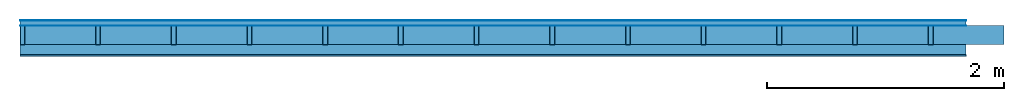
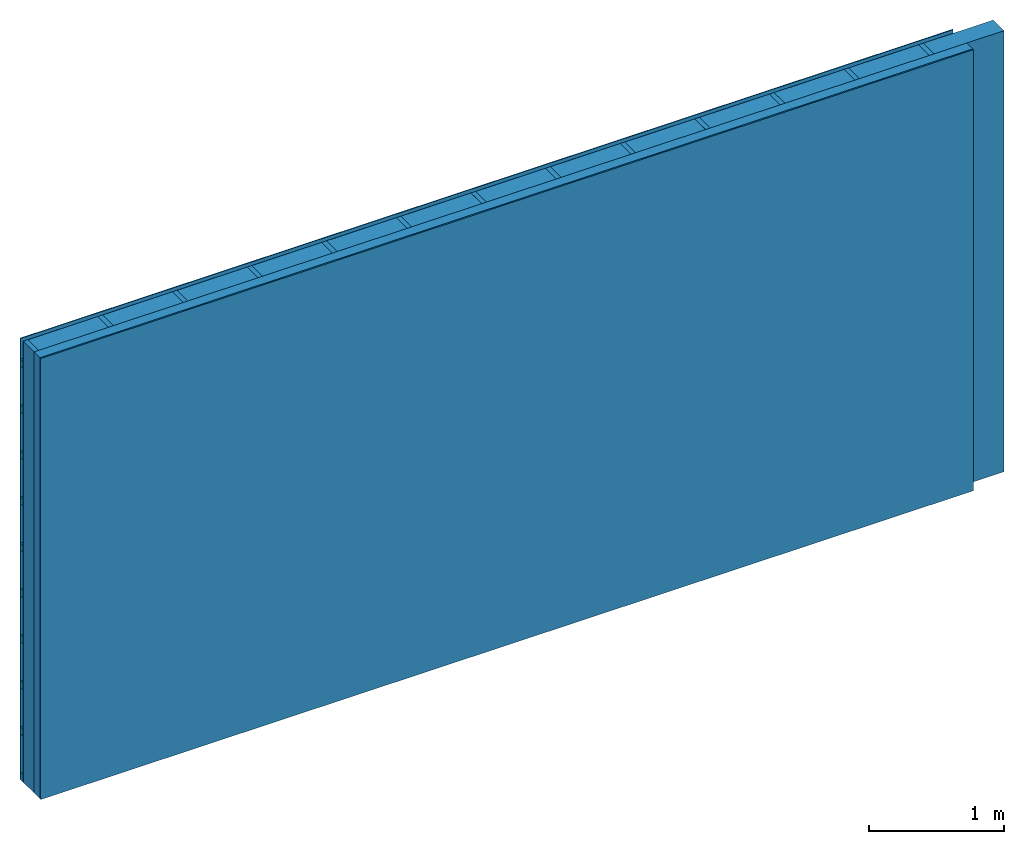
# One storey: 4 plates, 3 members, 1 element without a shape of its own.
"""IFC4 building model written with IfcOpenShell, lengths in metres."""

from ifc_helpers import new_model, si_unit, derived_unit, direction, frame, frame_2d, origin, origin_with_axes, place, context, project, spatial, rectangle, extrude, material, layer, layer_set, type_object, element, aggregate, save


model = new_model("IFC4")

# Units and contexts
plan_context = context("Plan", 3, precision=1e-05, world=origin(), true_north=direction((0.0, 1.0)))
model_context = context("Model", 3, precision=1e-05, world=origin(), true_north=direction((0.0, 1.0)))
ifc_project = project(units=[si_unit("LENGTHUNIT", "METRE"), derived_unit("SOUNDPRESSUREUNIT", [(si_unit("PRESSUREUNIT", "PASCAL", prefix="MICRO"), 0)]), si_unit("ENERGYUNIT", "JOULE", prefix="MEGA"), si_unit("MASSUNIT", "GRAM", prefix="KILO"), derived_unit("THERMALTRANSMITTANCEUNIT", [(si_unit("POWERUNIT", "WATT"), 1), (si_unit("AREAUNIT", "SQUARE_METRE"), -1), (si_unit("THERMODYNAMICTEMPERATUREUNIT", "KELVIN"), -1)]), derived_unit("AREADENSITYUNIT", [(si_unit("MASSUNIT", "GRAM", prefix="KILO"), 1), (si_unit("AREAUNIT", "SQUARE_METRE"), -1)]), derived_unit("USERDEFINED", [(si_unit("ENERGYUNIT", "JOULE", prefix="MEGA"), 1), (si_unit("AREAUNIT", "SQUARE_METRE"), -1)])], contexts=[plan_context, model_context])

# Site, building, storey
site = spatial("IfcSite", under=ifc_project)
building_placement = place(None, origin())
building = spatial("IfcBuilding", under=site, at=building_placement)
storey_placement = place(building_placement, origin())
storey = spatial("IfcBuildingStorey", under=building, at=storey_placement)

# Wall, members, plates
ifc_material_1 = material(Name="mineral, cement-based building board", Category="03.003")
ifc_layer_1 = layer(ifc_material_1, 0.008, Name="Cover 1st layer")
ifc_layer_2 = layer(None, 0.04, Name="Battens / profiles (ventilation)")
ifc_material_2 = material(Name="Vapor-permeable water barrier", Category="09.006")
ifc_layer_3 = layer(ifc_material_2, 0.0005, Name="outside 1st layer")
ifc_material_3 = material(Name="of the art")
ifc_layer_4 = layer(ifc_material_3, 0.0, Name="Bond")
ifc_layer_5 = layer(None, 0.16, Name="Support")
ifc_layer_6 = layer(ifc_material_3, 0.0, Name="Bond")
ifc_material_4 = material(Name="Solid timber panel")
ifc_layer_7 = layer(ifc_material_4, 0.087, Name="1st layer")
ifc_material_5 = material(Name="Plasterboard type A", Category="03.008")
ifc_layer_8 = layer(ifc_material_5, 0.0125, Name="Covering 1st layer")
ifc_material_6 = material(Name="joints", Category="04.017")
ifc_layer_9 = layer(ifc_material_6, 0.0, Name="Surface")
ifc_layer_set = layer_set([ifc_layer_1, ifc_layer_2, ifc_layer_3, ifc_layer_4, ifc_layer_5, ifc_layer_6, ifc_layer_7, ifc_layer_8, ifc_layer_9])
wall_type = type_object("IfcWallType", Name="D0994", PredefinedType="NOTDEFINED", material=ifc_layer_set)
wall_placement = place(None, frame((0.0, 0.0, 0.0), z_axis=(0.0, -1.0, 0.0), x_axis=(1.0, 0.0, 0.0)))
wall = element("IfcWall", 1, at=wall_placement, inside=storey, type_object=wall_type, material=ifc_layer_set, Name="Wall #1")
ifc_material_7 = material()
member_1_placement = place(wall_placement, origin())
member_1 = element("IfcMember", 2, at=member_1_placement, material=ifc_material_7, Name="Battens / profiles (ventilation)", context=plan_context, shape_type="SweptSolid", body=[
    extrude(rectangle(XDim=0.06, YDim=0.04, at=frame_2d((0.03, 0.02), x_axis=(1.0, 0.0))), frame((0.0, 0.0, 0.008), z_axis=(1.0, 0.0, 0.0), x_axis=(0.0, 1.0, 0.0)), (0.0, 0.0, 1.0), 8.0),
    extrude(rectangle(XDim=0.06, YDim=0.04, at=frame_2d((0.03, 0.02), x_axis=(1.0, 0.0))), frame((0.0, 0.417, 0.008), z_axis=(1.0, 0.0, 0.0), x_axis=(0.0, 1.0, 0.0)), (0.0, 0.0, 1.0), 8.0),
    extrude(rectangle(XDim=0.06, YDim=0.04, at=frame_2d((0.03, 0.02), x_axis=(1.0, 0.0))), frame((0.0, 0.834, 0.008), z_axis=(1.0, 0.0, 0.0), x_axis=(0.0, 1.0, 0.0)), (0.0, 0.0, 1.0), 8.0),
    extrude(rectangle(XDim=0.06, YDim=0.04, at=frame_2d((0.03, 0.02), x_axis=(1.0, 0.0))), frame((0.0, 1.251, 0.008), z_axis=(1.0, 0.0, 0.0), x_axis=(0.0, 1.0, 0.0)), (0.0, 0.0, 1.0), 8.0),
    extrude(rectangle(XDim=0.06, YDim=0.04, at=frame_2d((0.03, 0.02), x_axis=(1.0, 0.0))), frame((0.0, 1.668, 0.008), z_axis=(1.0, 0.0, 0.0), x_axis=(0.0, 1.0, 0.0)), (0.0, 0.0, 1.0), 8.0),
    extrude(rectangle(XDim=0.06, YDim=0.04, at=frame_2d((0.03, 0.02), x_axis=(1.0, 0.0))), frame((0.0, 2.085, 0.008), z_axis=(1.0, 0.0, 0.0), x_axis=(0.0, 1.0, 0.0)), (0.0, 0.0, 1.0), 8.0),
    extrude(rectangle(XDim=0.06, YDim=0.04, at=frame_2d((0.03, 0.02), x_axis=(1.0, 0.0))), frame((0.0, 2.502, 0.008), z_axis=(1.0, 0.0, 0.0), x_axis=(0.0, 1.0, 0.0)), (0.0, 0.0, 1.0), 8.0),
    extrude(rectangle(XDim=0.06, YDim=0.04, at=frame_2d((0.03, 0.02), x_axis=(1.0, 0.0))), frame((0.0, 2.919, 0.008), z_axis=(1.0, 0.0, 0.0), x_axis=(0.0, 1.0, 0.0)), (0.0, 0.0, 1.0), 8.0),
    extrude(rectangle(XDim=0.06, YDim=0.04, at=frame_2d((0.03, 0.02), x_axis=(1.0, 0.0))), frame((0.0, 3.336, 0.008), z_axis=(1.0, 0.0, 0.0), x_axis=(0.0, 1.0, 0.0)), (0.0, 0.0, 1.0), 8.0),
    extrude(rectangle(XDim=0.06, YDim=0.04, at=frame_2d((0.03, 0.02), x_axis=(1.0, 0.0))), frame((0.0, 3.753, 0.008), z_axis=(1.0, 0.0, 0.0), x_axis=(0.0, 1.0, 0.0)), (0.0, 0.0, 1.0), 8.0),
])
ifc_material_8 = material()
member_2_placement = place(wall_placement, origin())
member_2 = element("IfcMember", 3, at=member_2_placement, material=ifc_material_8, Name="Support", context=plan_context, shape_type="SweptSolid", body=[
    extrude(rectangle(XDim=0.04, YDim=0.16, at=frame_2d((0.02, 0.08), x_axis=(1.0, 0.0))), frame((0.0, 4.0, 0.0485), z_axis=(0.0, -1.0, 0.0), x_axis=(1.0, 0.0, 0.0)), (0.0, 0.0, 1.0), 4.0),
    extrude(rectangle(XDim=0.04, YDim=0.16, at=frame_2d((0.02, 0.08), x_axis=(1.0, 0.0))), frame((0.64, 4.0, 0.0485), z_axis=(0.0, -1.0, 0.0), x_axis=(1.0, 0.0, 0.0)), (0.0, 0.0, 1.0), 4.0),
    extrude(rectangle(XDim=0.04, YDim=0.16, at=frame_2d((0.02, 0.08), x_axis=(1.0, 0.0))), frame((1.28, 4.0, 0.0485), z_axis=(0.0, -1.0, 0.0), x_axis=(1.0, 0.0, 0.0)), (0.0, 0.0, 1.0), 4.0),
    extrude(rectangle(XDim=0.04, YDim=0.16, at=frame_2d((0.02, 0.08), x_axis=(1.0, 0.0))), frame((1.92, 4.0, 0.0485), z_axis=(0.0, -1.0, 0.0), x_axis=(1.0, 0.0, 0.0)), (0.0, 0.0, 1.0), 4.0),
    extrude(rectangle(XDim=0.04, YDim=0.16, at=frame_2d((0.02, 0.08), x_axis=(1.0, 0.0))), frame((2.56, 4.0, 0.0485), z_axis=(0.0, -1.0, 0.0), x_axis=(1.0, 0.0, 0.0)), (0.0, 0.0, 1.0), 4.0),
    extrude(rectangle(XDim=0.04, YDim=0.16, at=frame_2d((0.02, 0.08), x_axis=(1.0, 0.0))), frame((3.2, 4.0, 0.0485), z_axis=(0.0, -1.0, 0.0), x_axis=(1.0, 0.0, 0.0)), (0.0, 0.0, 1.0), 4.0),
    extrude(rectangle(XDim=0.04, YDim=0.16, at=frame_2d((0.02, 0.08), x_axis=(1.0, 0.0))), frame((3.84, 4.0, 0.0485), z_axis=(0.0, -1.0, 0.0), x_axis=(1.0, 0.0, 0.0)), (0.0, 0.0, 1.0), 4.0),
    extrude(rectangle(XDim=0.04, YDim=0.16, at=frame_2d((0.02, 0.08), x_axis=(1.0, 0.0))), frame((4.48, 4.0, 0.0485), z_axis=(0.0, -1.0, 0.0), x_axis=(1.0, 0.0, 0.0)), (0.0, 0.0, 1.0), 4.0),
    extrude(rectangle(XDim=0.04, YDim=0.16, at=frame_2d((0.02, 0.08), x_axis=(1.0, 0.0))), frame((5.12, 4.0, 0.0485), z_axis=(0.0, -1.0, 0.0), x_axis=(1.0, 0.0, 0.0)), (0.0, 0.0, 1.0), 4.0),
    extrude(rectangle(XDim=0.04, YDim=0.16, at=frame_2d((0.02, 0.08), x_axis=(1.0, 0.0))), frame((5.76, 4.0, 0.0485), z_axis=(0.0, -1.0, 0.0), x_axis=(1.0, 0.0, 0.0)), (0.0, 0.0, 1.0), 4.0),
    extrude(rectangle(XDim=0.04, YDim=0.16, at=frame_2d((0.02, 0.08), x_axis=(1.0, 0.0))), frame((6.4, 4.0, 0.0485), z_axis=(0.0, -1.0, 0.0), x_axis=(1.0, 0.0, 0.0)), (0.0, 0.0, 1.0), 4.0),
    extrude(rectangle(XDim=0.04, YDim=0.16, at=frame_2d((0.02, 0.08), x_axis=(1.0, 0.0))), frame((7.04, 4.0, 0.0485), z_axis=(0.0, -1.0, 0.0), x_axis=(1.0, 0.0, 0.0)), (0.0, 0.0, 1.0), 4.0),
    extrude(rectangle(XDim=0.04, YDim=0.16, at=frame_2d((0.02, 0.08), x_axis=(1.0, 0.0))), frame((7.68, 4.0, 0.0485), z_axis=(0.0, -1.0, 0.0), x_axis=(1.0, 0.0, 0.0)), (0.0, 0.0, 1.0), 4.0),
])
ifc_material_9 = material(Name="Mineral wool")
member_3_placement = place(wall_placement, origin())
member_3 = element("IfcMember", 4, at=member_3_placement, material=ifc_material_9, Name="Cavity", context=plan_context, shape_type="SweptSolid", body=[
    extrude(rectangle(XDim=0.6, YDim=0.16, at=frame_2d((0.3, 0.08), x_axis=(1.0, 0.0))), frame((0.04, 4.0, 0.0485), z_axis=(0.0, -1.0, 0.0), x_axis=(1.0, 0.0, 0.0)), (0.0, 0.0, 1.0), 4.0),
    extrude(rectangle(XDim=0.6, YDim=0.16, at=frame_2d((0.3, 0.08), x_axis=(1.0, 0.0))), frame((0.68, 4.0, 0.0485), z_axis=(0.0, -1.0, 0.0), x_axis=(1.0, 0.0, 0.0)), (0.0, 0.0, 1.0), 4.0),
    extrude(rectangle(XDim=0.6, YDim=0.16, at=frame_2d((0.3, 0.08), x_axis=(1.0, 0.0))), frame((1.32, 4.0, 0.0485), z_axis=(0.0, -1.0, 0.0), x_axis=(1.0, 0.0, 0.0)), (0.0, 0.0, 1.0), 4.0),
    extrude(rectangle(XDim=0.6, YDim=0.16, at=frame_2d((0.3, 0.08), x_axis=(1.0, 0.0))), frame((1.96, 4.0, 0.0485), z_axis=(0.0, -1.0, 0.0), x_axis=(1.0, 0.0, 0.0)), (0.0, 0.0, 1.0), 4.0),
    extrude(rectangle(XDim=0.6, YDim=0.16, at=frame_2d((0.3, 0.08), x_axis=(1.0, 0.0))), frame((2.6, 4.0, 0.0485), z_axis=(0.0, -1.0, 0.0), x_axis=(1.0, 0.0, 0.0)), (0.0, 0.0, 1.0), 4.0),
    extrude(rectangle(XDim=0.6, YDim=0.16, at=frame_2d((0.3, 0.08), x_axis=(1.0, 0.0))), frame((3.24, 4.0, 0.0485), z_axis=(0.0, -1.0, 0.0), x_axis=(1.0, 0.0, 0.0)), (0.0, 0.0, 1.0), 4.0),
    extrude(rectangle(XDim=0.6, YDim=0.16, at=frame_2d((0.3, 0.08), x_axis=(1.0, 0.0))), frame((3.88, 4.0, 0.0485), z_axis=(0.0, -1.0, 0.0), x_axis=(1.0, 0.0, 0.0)), (0.0, 0.0, 1.0), 4.0),
    extrude(rectangle(XDim=0.6, YDim=0.16, at=frame_2d((0.3, 0.08), x_axis=(1.0, 0.0))), frame((4.52, 4.0, 0.0485), z_axis=(0.0, -1.0, 0.0), x_axis=(1.0, 0.0, 0.0)), (0.0, 0.0, 1.0), 4.0),
    extrude(rectangle(XDim=0.6, YDim=0.16, at=frame_2d((0.3, 0.08), x_axis=(1.0, 0.0))), frame((5.16, 4.0, 0.0485), z_axis=(0.0, -1.0, 0.0), x_axis=(1.0, 0.0, 0.0)), (0.0, 0.0, 1.0), 4.0),
    extrude(rectangle(XDim=0.6, YDim=0.16, at=frame_2d((0.3, 0.08), x_axis=(1.0, 0.0))), frame((5.8, 4.0, 0.0485), z_axis=(0.0, -1.0, 0.0), x_axis=(1.0, 0.0, 0.0)), (0.0, 0.0, 1.0), 4.0),
    extrude(rectangle(XDim=0.6, YDim=0.16, at=frame_2d((0.3, 0.08), x_axis=(1.0, 0.0))), frame((6.44, 4.0, 0.0485), z_axis=(0.0, -1.0, 0.0), x_axis=(1.0, 0.0, 0.0)), (0.0, 0.0, 1.0), 4.0),
    extrude(rectangle(XDim=0.6, YDim=0.16, at=frame_2d((0.3, 0.08), x_axis=(1.0, 0.0))), frame((7.08, 4.0, 0.0485), z_axis=(0.0, -1.0, 0.0), x_axis=(1.0, 0.0, 0.0)), (0.0, 0.0, 1.0), 4.0),
    extrude(rectangle(XDim=0.6, YDim=0.16, at=frame_2d((0.3, 0.08), x_axis=(1.0, 0.0))), frame((7.72, 4.0, 0.0485), z_axis=(0.0, -1.0, 0.0), x_axis=(1.0, 0.0, 0.0)), (0.0, 0.0, 1.0), 4.0),
])
plate_1_placement = place(wall_placement, origin())
plate_1 = element("IfcPlate", 5, at=plate_1_placement, material=ifc_material_1, Name="Cover 1st layer", context=plan_context, shape_type="SweptSolid", body=[
    extrude(rectangle(XDim=8.0, YDim=4.0, at=frame_2d((4.0, 2.0), x_axis=(1.0, 0.0))), origin_with_axes(), (0.0, 0.0, 1.0), 0.008),
])
plate_2_placement = place(wall_placement, origin())
plate_2 = element("IfcPlate", 6, at=plate_2_placement, material=ifc_material_2, Name="outside 1st layer", context=plan_context, shape_type="SweptSolid", body=[
    extrude(rectangle(XDim=8.0, YDim=4.0, at=frame_2d((4.0, 2.0), x_axis=(1.0, 0.0))), frame((0.0, 0.0, 0.048), z_axis=(0.0, 0.0, 1.0), x_axis=(1.0, 0.0, 0.0)), (0.0, 0.0, 1.0), 0.0005),
])
plate_3_placement = place(wall_placement, origin())
plate_3 = element("IfcPlate", 7, at=plate_3_placement, material=ifc_material_4, Name="1st layer", context=plan_context, shape_type="SweptSolid", body=[
    extrude(rectangle(XDim=8.0, YDim=4.0, at=frame_2d((4.0, 2.0), x_axis=(1.0, 0.0))), frame((0.0, 0.0, 0.2085), z_axis=(0.0, 0.0, 1.0), x_axis=(1.0, 0.0, 0.0)), (0.0, 0.0, 1.0), 0.087),
])
plate_4_placement = place(wall_placement, origin())
plate_4 = element("IfcPlate", 8, at=plate_4_placement, material=ifc_material_5, Name="Covering 1st layer", context=plan_context, shape_type="SweptSolid", body=[
    extrude(rectangle(XDim=8.0, YDim=4.0, at=frame_2d((4.0, 2.0), x_axis=(1.0, 0.0))), frame((0.0, 0.0, 0.2955), z_axis=(0.0, 0.0, 1.0), x_axis=(1.0, 0.0, 0.0)), (0.0, 0.0, 1.0), 0.0125),
])
aggregate(wall, [plate_1, member_1, plate_2, member_2, member_3, plate_3, plate_4])

save(model, "model.ifc")
